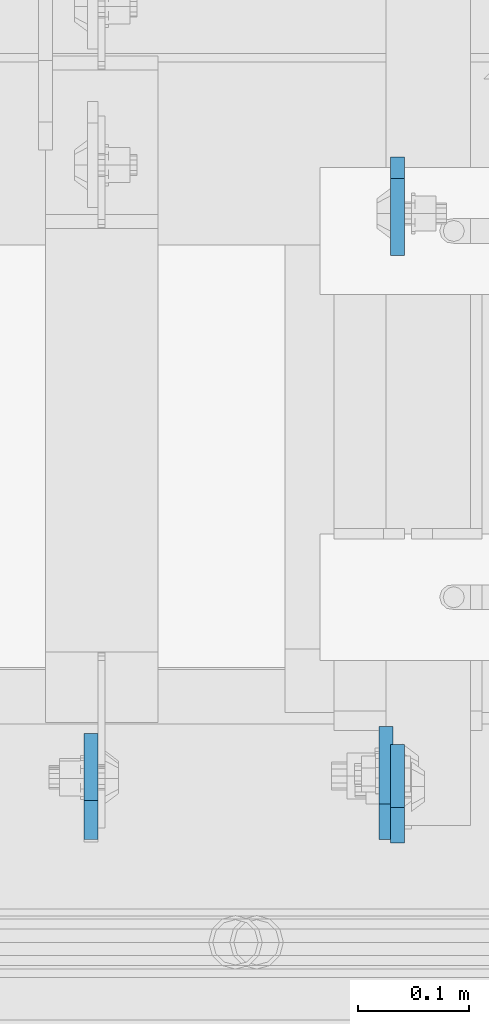
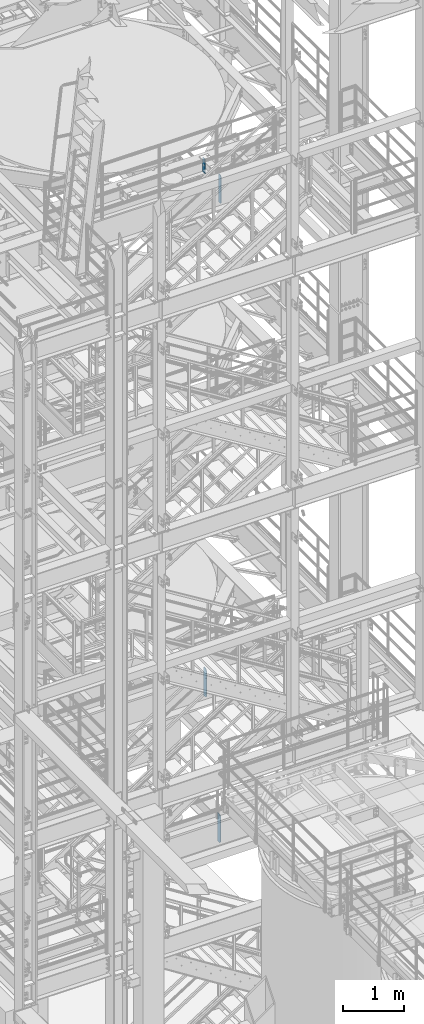
# One storey, part 1498 of 1876: 4 plates, 4 elements without a shape of their own.
"""IFC2X3 building model written with IfcOpenShell, lengths in millimetres."""

from ifc_helpers import new_model, si_unit, frame, origin_with_axes, place, context, subcontext, project, spatial, faceted_brep, material, type_object, element, aggregate, save


model = new_model("IFC2X3")

# Units and contexts
model_context = context("Model", 3, precision=1e-05, world=origin_with_axes())
body_context = subcontext(model_context, "Body", "Model", "MODEL_VIEW")
ifc_project = project(units=[si_unit("LENGTHUNIT", "METRE", prefix="MILLI"), si_unit("AREAUNIT", "SQUARE_METRE"), si_unit("VOLUMEUNIT", "CUBIC_METRE"), si_unit("MASSUNIT", "GRAM", prefix="KILO"), si_unit("TIMEUNIT", "SECOND"), si_unit("PLANEANGLEUNIT", "RADIAN"), si_unit("SOLIDANGLEUNIT", "STERADIAN"), si_unit("THERMODYNAMICTEMPERATUREUNIT", "DEGREE_CELSIUS"), si_unit("LUMINOUSINTENSITYUNIT", "LUMEN")], contexts=[model_context])

# Site, building, storey
site_placement = place(None, origin_with_axes())
site = spatial("IfcSite", under=ifc_project, at=site_placement, CompositionType="ELEMENT")
building_placement = place(site_placement, origin_with_axes())
building = spatial("IfcBuilding", under=site, at=building_placement, Name="Undefined", CompositionType="ELEMENT")
storey_placement = place(building_placement, origin_with_axes())
storey = spatial("IfcBuildingStorey", under=building, at=storey_placement, Name="Undefined", CompositionType="ELEMENT", Elevation=0.0)

# Assembly, plate
assembly_1_placement = place(storey_placement, origin_with_axes())
assembly_1 = element("IfcElementAssembly", 1, at=assembly_1_placement, inside=storey, Name="BEAM", AssemblyPlace="NOTDEFINED", PredefinedType="RIGID_FRAME")
ifc_material = material(Name="STEEL/A36")
plate_type_1 = type_object("IfcPlateType", PredefinedType="NOTDEFINED")
plate_1_placement = place(assembly_1_placement, frame((5194.29999990463, -4564.85625, 17386.3), z_axis=(0.0, 0.0, 1.0), x_axis=(0.0, 1.0, 0.0)))
plate_1 = element("IfcPlate", 2, at=plate_1_placement, type_object=plate_type_1, material=ifc_material, Name="PLATE", context=body_context, shape_type="Brep", body=[
    faceted_brep([(0.0, -6.34999999999991, 31.75), (0.0, -6.34999999999991, 539.75), (0.0, 6.34999999999991, 539.75), (0.0, 6.34999999999991, 31.75), (31.75, -6.34999999999991, 571.5), (31.75, 6.34999999999991, 571.5), (88.9000015258789, -6.34999999999991, 571.5), (88.9000015258789, 6.34999999999991, 571.5), (88.9000015258789, -6.34999999999991, 0.0), (88.9000015258789, 6.34999999999991, 0.0), (31.75, -6.34999999999991, 0.0), (31.75, 6.34999999999991, 0.0)], [[[0, 1, 2, 3]], [[1, 4, 5, 2]], [[4, 6, 7, 5]], [[6, 8, 9, 7]], [[8, 10, 11, 9]], [[10, 0, 3, 11]], [[5, 7, 9, 11, 3, 2]], [[10, 8, 6, 4, 1, 0]]]),
])
aggregate(assembly_1, [plate_1])

assembly_2_placement = place(storey_placement, origin_with_axes())
assembly_2 = element("IfcElementAssembly", 3, at=assembly_2_placement, inside=storey, Name="BEAM", AssemblyPlace="NOTDEFINED", PredefinedType="RIGID_FRAME")
plate_2_placement = place(assembly_2_placement, frame((5194.29999989042, -3946.525, 17681.575), z_axis=(0.0, 0.0, 1.0), x_axis=(0.0, -1.0, 0.0)))
plate_2 = element("IfcPlate", 4, at=plate_2_placement, type_object=plate_type_1, material=ifc_material, Name="PLATE", context=body_context, shape_type="Brep", body=[
    faceted_brep([(0.0, -6.35000000000196, 19.0499992370605), (0.0, -6.35000000000036, 271.462512969971), (0.0, 6.35000000000036, 271.462512969971), (0.0, 6.35000000000105, 19.0499992370605), (19.0499992370605, -6.35000000000036, 290.512512207031), (19.0499992370605, 6.35000000000036, 290.512512207031), (88.9000015258789, -6.35000000000036, 290.512512207031), (88.9000015258789, 6.35000000000036, 290.512512207031), (88.9000015258789, -6.34999999999991, 0.0), (88.9000015258789, 6.34999999999991, 0.0), (19.0499992370642, -6.35000000000105, 0.0), (19.0499992370633, 6.35000000000105, 0.0)], [[[0, 1, 2, 3]], [[1, 4, 5, 2]], [[4, 6, 7, 5]], [[6, 8, 9, 7]], [[8, 10, 11, 9]], [[10, 0, 3, 11]], [[5, 7, 9, 11, 3, 2]], [[10, 8, 6, 4, 1, 0]]]),
])
aggregate(assembly_2, [plate_2])

assembly_3_placement = place(storey_placement, origin_with_axes())
assembly_3 = element("IfcElementAssembly", 5, at=assembly_3_placement, inside=storey, Name="BEAM", AssemblyPlace="NOTDEFINED", PredefinedType="RIGID_FRAME")
plate_type_2 = type_object("IfcPlateType", PredefinedType="NOTDEFINED")
plate_3_placement = place(assembly_3_placement, frame((4918.07499990463, -4561.68125, 7543.8), z_axis=(0.0, 0.0, 1.0), x_axis=(0.0, 1.0, 0.0)))
plate_3 = element("IfcPlate", 6, at=plate_3_placement, type_object=plate_type_2, material=ifc_material, Name="PLATE", context=body_context, shape_type="Brep", body=[
    faceted_brep([(0.0, -6.34999999999991, 34.9249992370605), (0.0, -6.35000000000036, 538.162475585938), (0.0, 6.35000000000036, 538.162475585938), (0.0, 6.34999999999991, 34.9249992370605), (34.9249992370605, -6.34999999999991, 573.087524414062), (34.9249992370605, 6.34999999999991, 573.087524414062), (95.25, -6.34999999999991, 573.087524414062), (95.25, 6.34999999999991, 573.087524414062), (95.25, -6.35000000000036, 0.0), (95.25, 6.35000000000036, 0.0), (34.9249992370605, -6.34999999999991, 0.0), (34.9249992370605, 6.34999999999991, 0.0)], [[[0, 1, 2, 3]], [[1, 4, 5, 2]], [[4, 6, 7, 5]], [[6, 8, 9, 7]], [[8, 10, 11, 9]], [[10, 0, 3, 11]], [[5, 7, 9, 11, 3, 2]], [[10, 8, 6, 4, 1, 0]]]),
])
aggregate(assembly_3, [plate_3])

assembly_4_placement = place(storey_placement, origin_with_axes())
assembly_4 = element("IfcElementAssembly", 7, at=assembly_4_placement, inside=storey, Name="BEAM", AssemblyPlace="NOTDEFINED", PredefinedType="RIGID_FRAME")
plate_type_3 = type_object("IfcPlateType", PredefinedType="NOTDEFINED")
plate_4_placement = place(assembly_4_placement, frame((5183.98124990463, -4561.68125, 4521.2), z_axis=(0.0, 0.0, 1.0), x_axis=(0.0, 1.0, 0.0)))
plate_4 = element("IfcPlate", 8, at=plate_4_placement, type_object=plate_type_3, material=ifc_material, Name="PLATE", context=body_context, shape_type="Brep", body=[
    faceted_brep([(0.0, -6.34999999999991, 31.75), (0.0, -6.35000000000036, 541.337524414062), (0.0, 6.35000000000036, 541.337524414062), (0.0, 6.34999999999991, 31.75), (31.75, -6.35000000000036, 573.087524414062), (31.75, 6.35000000000036, 573.087524414062), (101.599998474121, -6.35000000000036, 573.087524414062), (101.599998474121, 6.35000000000036, 573.087524414062), (101.599998474121, -6.35000000000036, 0.0), (101.599998474121, 6.35000000000036, 0.0), (31.75, -6.34999999999991, 0.0), (31.75, 6.34999999999991, 0.0)], [[[0, 1, 2, 3]], [[1, 4, 5, 2]], [[4, 6, 7, 5]], [[6, 8, 9, 7]], [[8, 10, 11, 9]], [[10, 0, 3, 11]], [[5, 7, 9, 11, 3, 2]], [[10, 8, 6, 4, 1, 0]]]),
])
aggregate(assembly_4, [plate_4])

save(model, "model.ifc")
